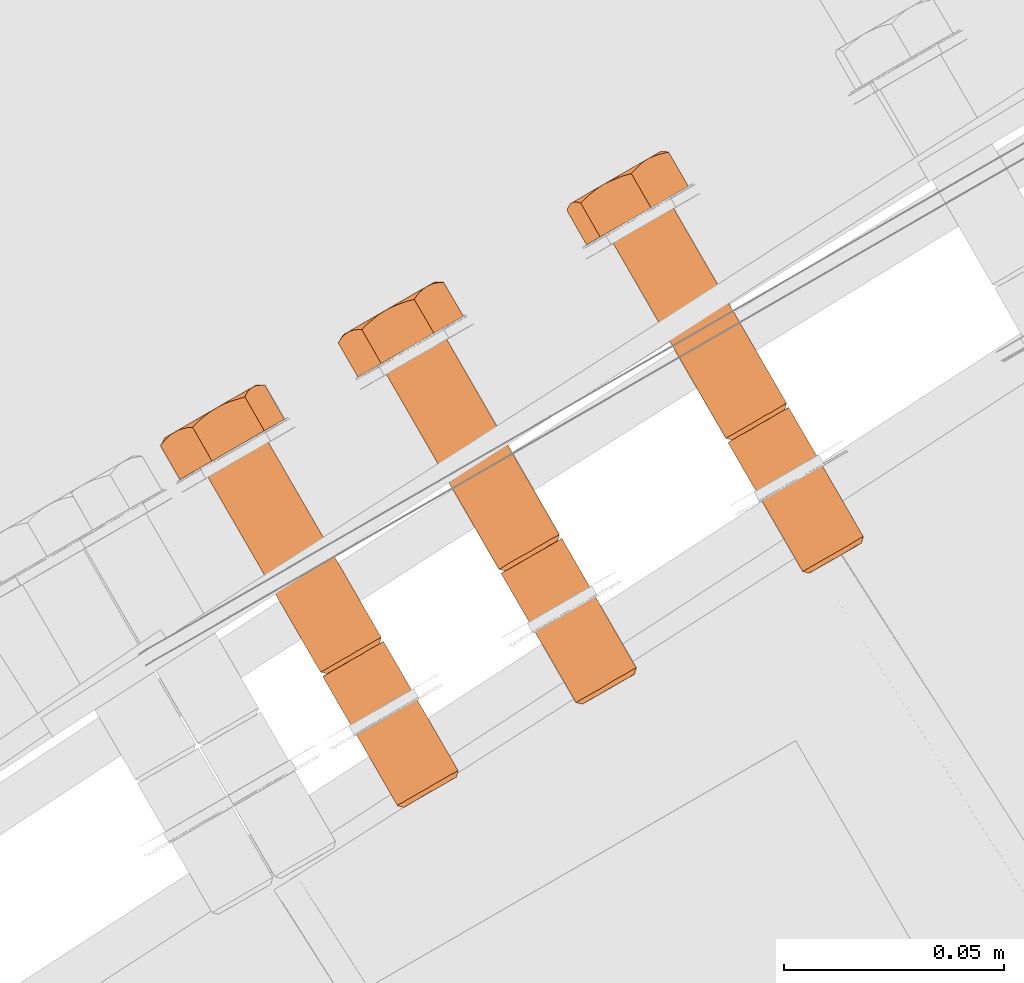
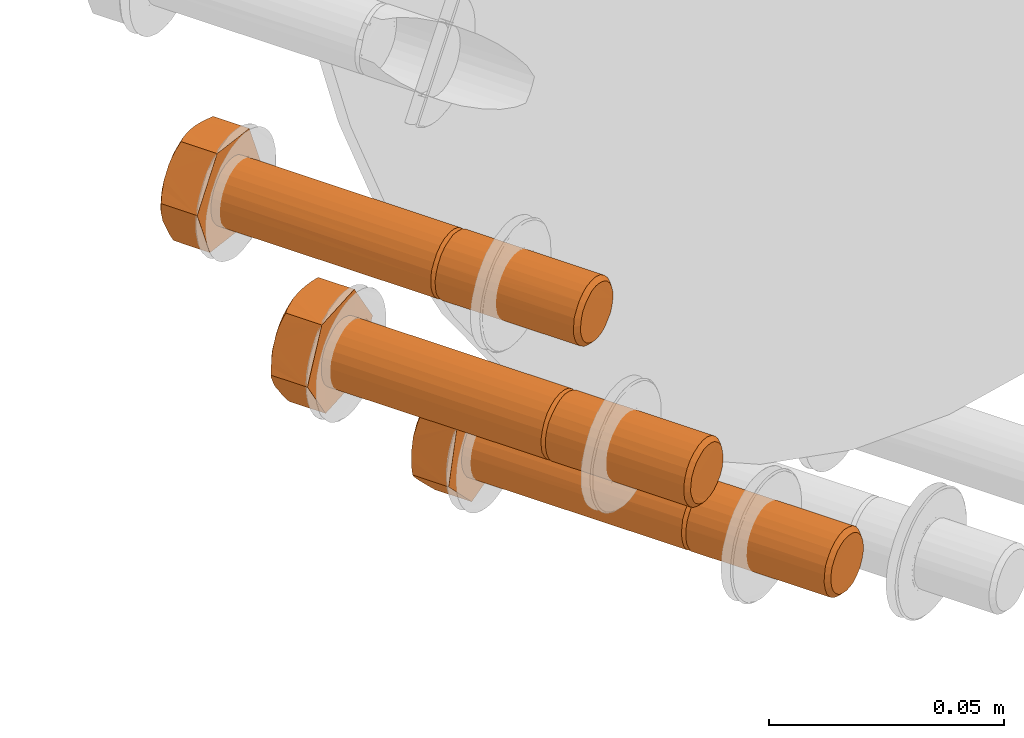
# One storey, part 76 of 126: 3 proxies.
"""IFC2X3 building model written with IfcOpenShell, lengths in millimetres."""

from ifc_helpers import new_model, si_unit, origin, origin_with_axes, place, context, project, spatial, faceted_brep, material, element, save


model = new_model("IFC2X3")

# Units and contexts
context_of_model_1 = context(None, 3, precision=0.1, world=origin())
context_of_model_2 = context(None, 3, precision=0.1, world=origin())
ifc_project = project(units=[si_unit("LENGTHUNIT", "METRE", prefix="MILLI"), si_unit("AREAUNIT", "SQUARE_METRE", prefix="CENTI"), si_unit("VOLUMEUNIT", "CUBIC_METRE", prefix="CENTI"), si_unit("MASSUNIT", "GRAM", prefix="KILO")], contexts=[context_of_model_1, context_of_model_2])

# Site, building, storey
site_placement = place(None, origin_with_axes())
site = spatial("IfcSite", under=ifc_project, at=site_placement, CompositionType="ELEMENT")
building_placement = place(site_placement, origin_with_axes())
building = spatial("IfcBuilding", under=site, at=building_placement, CompositionType="ELEMENT")
storey_placement = place(building_placement, origin_with_axes())
storey = spatial("IfcBuildingStorey", under=building, at=storey_placement, CompositionType="ELEMENT")

# Proxies
ifc_material = material(Name="STAHL")
proxy_1_placement = place(storey_placement, origin_with_axes())
element("IfcBuildingElementProxy", 1, at=proxy_1_placement, inside=storey, material=ifc_material, Name="profile", context=context_of_model_2, shape_type="Brep", body=[
    faceted_brep([(3788.3, 14751.2, 560.0), (3786.9, 14751.6, 559.5), (3788.0, 14752.2, 557.9), (3789.2, 14751.7, 558.7), (3787.7, 14750.8, 561.5), (3786.3, 14751.2, 561.2), (3787.4, 14750.7, 563.2), (3786.0, 14751.1, 563.1), (3787.5, 14750.7, 564.9), (3786.1, 14751.1, 565.0), (3787.9, 14751.0, 566.4), (3786.5, 14751.4, 566.9), (3788.7, 14751.4, 567.9), (3787.4, 14751.9, 568.5), (3789.7, 14752.0, 569.1), (3788.6, 14752.6, 569.9), (3790.9, 14752.7, 569.9), (3790.0, 14753.4, 570.9), (3792.3, 14753.5, 570.4), (3791.6, 14754.3, 571.5), (3793.8, 14754.3, 570.5), (3793.3, 14755.3, 571.6), (3795.2, 14755.1, 570.2), (3794.9, 14756.2, 571.2), (3796.5, 14755.9, 569.5), (3796.5, 14757.1, 570.5), (3797.6, 14756.6, 568.5), (3797.8, 14757.9, 569.3), (3769.4, 14781.9, 559.5), (3770.5, 14782.5, 557.9), (3771.7, 14782.0, 558.7), (3770.8, 14781.5, 560.0), (3768.8, 14781.5, 561.2), (3770.2, 14781.1, 561.5), (3768.5, 14781.4, 563.1), (3769.9, 14781.0, 563.2), (3768.6, 14781.4, 565.0), (3770.0, 14781.0, 564.9), (3769.0, 14781.7, 566.9), (3770.4, 14781.3, 566.4), (3769.9, 14782.2, 568.5), (3771.2, 14781.7, 567.9), (3771.1, 14782.9, 569.9), (3772.2, 14782.3, 569.1), (3772.5, 14783.7, 570.9), (3773.4, 14783.0, 569.9), (3774.1, 14784.6, 571.5), (3774.8, 14783.8, 570.4), (3775.8, 14785.6, 571.6), (3776.3, 14784.6, 570.5), (3777.4, 14786.6, 571.2), (3777.7, 14785.5, 570.2), (3779.0, 14787.4, 570.5), (3779.0, 14786.2, 569.5), (3780.3, 14788.2, 569.3), (3780.1, 14786.9, 568.5), (3771.0, 14781.6, 557.9), (3772.3, 14782.4, 556.8), (3789.3, 14753.0, 556.8), (3798.8, 14758.5, 567.7), (3781.8, 14787.8, 567.7), (3780.8, 14787.3, 569.3), (3799.5, 14758.9, 566.0), (3782.5, 14788.2, 566.0), (3799.8, 14759.0, 564.1), (3782.8, 14788.4, 564.1), (3799.7, 14759.0, 562.2), (3782.7, 14788.4, 562.2), (3799.2, 14758.7, 560.3), (3782.2, 14788.1, 560.3), (3798.3, 14758.2, 558.7), (3781.4, 14787.6, 558.7), (3797.1, 14757.5, 557.3), (3780.2, 14786.9, 557.3), (3795.7, 14756.7, 556.3), (3778.8, 14786.1, 556.3), (3794.1, 14755.8, 555.7), (3777.2, 14785.1, 555.7), (3792.4, 14754.8, 555.6), (3775.5, 14784.2, 555.6), (3790.8, 14753.9, 556.0), (3773.8, 14783.2, 556.0), (3742.5, 14828.6, 559.5), (3743.5, 14829.2, 557.9), (3741.8, 14828.2, 561.2), (3741.5, 14828.1, 563.1), (3741.6, 14828.1, 565.0), (3742.1, 14828.4, 566.9), (3743.0, 14828.9, 568.5), (3744.1, 14829.6, 569.9), (3745.6, 14830.4, 570.9), (3747.2, 14831.3, 571.5), (3748.8, 14832.3, 571.6), (3750.5, 14833.2, 571.2), (3752.0, 14834.1, 570.5), (3753.3, 14834.9, 569.3), (3771.8, 14783.3, 556.8), (3744.8, 14830.0, 556.8), (3746.3, 14830.9, 556.0), (3773.3, 14784.2, 556.0), (3781.3, 14788.8, 567.7), (3754.3, 14835.5, 567.7), (3782.0, 14789.2, 566.0), (3755.0, 14835.9, 566.0), (3782.3, 14789.4, 564.1), (3755.3, 14836.0, 564.1), (3782.2, 14789.3, 562.2), (3755.2, 14836.0, 562.2), (3781.7, 14789.0, 560.3), (3754.7, 14835.7, 560.3), (3780.8, 14788.5, 558.7), (3753.9, 14835.2, 558.7), (3779.6, 14787.8, 557.3), (3752.7, 14834.5, 557.3), (3778.2, 14787.0, 556.3), (3751.3, 14833.7, 556.3), (3776.6, 14786.1, 555.7), (3749.7, 14832.8, 555.7), (3774.9, 14785.1, 555.6), (3748.0, 14831.8, 555.6), (3736.8, 14825.4, 560.0), (3745.3, 14830.3, 550.2), (3756.9, 14837.0, 553.8), (3760.0, 14838.7, 567.2), (3751.5, 14833.8, 577.0), (3739.9, 14827.2, 573.4), (3752.4, 14844.7, 553.8), (3752.6, 14845.4, 555.7), (3752.9, 14845.9, 557.6), (3753.1, 14846.3, 559.0), (3753.4, 14846.5, 560.5), (3753.9, 14846.7, 562.3), (3754.5, 14846.7, 564.2), (3755.0, 14846.6, 565.6), (3755.5, 14846.5, 567.2), (3751.7, 14845.4, 571.0), (3752.7, 14845.8, 569.9), (3754.1, 14846.2, 568.6), (3753.8, 14846.7, 562.6), (3753.8, 14846.7, 564.7), (3753.4, 14846.5, 566.7), (3752.8, 14846.2, 568.7), (3751.9, 14845.6, 570.5), (3750.8, 14845.0, 572.1), (3746.1, 14842.3, 552.0), (3747.8, 14843.3, 552.7), (3749.4, 14844.2, 553.8), (3750.8, 14845.0, 555.1), (3751.9, 14845.6, 556.7), (3752.8, 14846.2, 558.5), (3750.9, 14844.3, 553.4), (3749.4, 14843.8, 553.0), (3747.7, 14843.1, 552.5), (3736.1, 14836.5, 555.1), (3737.4, 14837.3, 553.8), (3739.0, 14838.2, 552.7), (3740.7, 14839.2, 552.0), (3742.5, 14840.2, 551.7), (3744.3, 14841.2, 551.7), (3744.9, 14841.5, 551.6), (3743.7, 14840.6, 551.2), (3742.2, 14839.4, 550.7), (3740.8, 14838.0, 550.2), (3739.7, 14837.8, 551.3), (3738.6, 14837.5, 552.4), (3737.3, 14837.1, 553.8), (3749.6, 14844.2, 573.4), (3748.6, 14843.3, 574.8), (3747.8, 14842.5, 575.9), (3747.0, 14841.6, 577.0), (3745.1, 14841.1, 576.5), (3743.4, 14840.4, 576.0), (3742.0, 14839.8, 575.6), (3740.7, 14839.2, 575.2), (3739.2, 14838.2, 574.7), (3737.7, 14837.0, 574.2), (3736.6, 14836.0, 573.8), (3735.5, 14834.9, 573.4), (3732.4, 14833.1, 560.0), (3732.5, 14833.7, 561.6), (3732.7, 14834.1, 563.1), (3733.0, 14834.6, 564.9), (3733.4, 14834.9, 566.7), (3733.1, 14834.7, 564.7), (3733.1, 14834.7, 562.6), (3733.4, 14834.9, 560.5), (3734.0, 14835.3, 558.5), (3734.9, 14835.8, 556.7), (3735.2, 14835.9, 556.2), (3734.3, 14835.2, 557.3), (3733.3, 14834.2, 558.6), (3739.0, 14838.2, 574.5), (3737.4, 14837.3, 573.4), (3736.1, 14836.5, 572.1), (3734.9, 14835.8, 570.5), (3734.0, 14835.3, 568.7), (3734.2, 14835.1, 569.6), (3734.8, 14835.1, 571.5), (3733.7, 14835.1, 568.2), (3749.4, 14844.2, 573.4), (3747.8, 14843.3, 574.5), (3746.1, 14842.3, 575.2), (3744.3, 14841.2, 575.6), (3742.5, 14840.2, 575.6), (3769.0, 14780.4, 563.1), (3769.1, 14780.5, 565.0), (3769.6, 14780.8, 566.9), (3770.5, 14781.3, 568.5), (3771.6, 14782.0, 569.9), (3773.1, 14782.8, 570.9), (3774.7, 14783.7, 571.5), (3776.3, 14784.7, 571.6), (3778.0, 14785.6, 571.2), (3779.5, 14786.5, 570.5), (3770.0, 14781.0, 559.5), (3772.8, 14782.6, 557.7), (3774.1, 14783.4, 557.0), (3775.5, 14784.2, 556.7), (3777.0, 14785.0, 556.8), (3778.4, 14785.8, 557.3), (3779.6, 14786.6, 558.2), (3780.6, 14787.1, 559.3), (3781.4, 14787.6, 560.8), (3781.8, 14787.8, 562.4), (3781.9, 14787.9, 564.0), (3781.6, 14787.7, 565.7), (3781.0, 14787.4, 567.2), (3769.3, 14780.6, 561.2), (3790.3, 14752.3, 557.7), (3791.6, 14753.1, 557.0), (3793.0, 14753.9, 556.7), (3794.5, 14754.7, 556.8), (3795.9, 14755.5, 557.3), (3797.1, 14756.2, 558.2), (3798.1, 14756.8, 559.3), (3798.9, 14757.3, 560.8), (3799.3, 14757.5, 562.4), (3799.4, 14757.6, 564.0), (3799.1, 14757.4, 565.7), (3798.5, 14757.1, 567.2)], [[[0, 1, 2, 3]], [[4, 5, 1, 0]], [[6, 7, 5, 4]], [[8, 9, 7, 6]], [[10, 11, 9, 8]], [[12, 13, 11, 10]], [[14, 15, 13, 12]], [[16, 17, 15, 14]], [[18, 19, 17, 16]], [[20, 21, 19, 18]], [[22, 23, 21, 20]], [[24, 25, 23, 22]], [[26, 27, 25, 24]], [[28, 29, 30, 31]], [[32, 28, 31, 33]], [[34, 32, 33, 35]], [[36, 34, 35, 37]], [[38, 36, 37, 39]], [[40, 38, 39, 41]], [[42, 40, 41, 43]], [[44, 42, 43, 45]], [[46, 44, 45, 47]], [[48, 46, 47, 49]], [[50, 48, 49, 51]], [[52, 50, 51, 53]], [[54, 52, 53, 55]], [[2, 56, 57, 58]], [[59, 60, 61, 27]], [[62, 63, 60, 59]], [[64, 65, 63, 62]], [[66, 67, 65, 64]], [[68, 69, 67, 66]], [[70, 71, 69, 68]], [[72, 73, 71, 70]], [[74, 75, 73, 72]], [[76, 77, 75, 74]], [[78, 79, 77, 76]], [[80, 81, 79, 78]], [[58, 57, 81, 80]], [[29, 28, 82, 83]], [[28, 32, 84, 82]], [[32, 34, 85, 84]], [[34, 36, 86, 85]], [[36, 38, 87, 86]], [[38, 40, 88, 87]], [[40, 42, 89, 88]], [[42, 44, 90, 89]], [[44, 46, 91, 90]], [[46, 48, 92, 91]], [[48, 50, 93, 92]], [[50, 52, 94, 93]], [[54, 95, 94, 52]], [[96, 29, 83, 97]], [[96, 97, 98, 99]], [[54, 100, 101, 95]], [[102, 103, 101, 100]], [[104, 105, 103, 102]], [[106, 107, 105, 104]], [[108, 109, 107, 106]], [[110, 111, 109, 108]], [[112, 113, 111, 110]], [[114, 115, 113, 112]], [[116, 117, 115, 114]], [[118, 119, 117, 116]], [[99, 98, 119, 118]], [[120, 121, 122, 123, 124, 125, 120, 86, 87, 88, 89, 90, 91, 92, 93, 94, 95, 101, 103, 105, 107, 109, 111, 113, 115, 117, 119, 98, 97, 83, 82, 84, 85, 86]], [[122, 126, 127, 128, 129, 130, 131, 132, 133, 134, 123]], [[135, 136, 137, 134, 133, 132, 131, 130, 138, 139, 140, 141, 142]], [[143, 135, 142]], [[144, 145, 146, 147, 148, 149, 128, 127, 126, 150, 151, 152]], [[129, 128, 149]], [[130, 129, 149]], [[153, 154, 155, 156, 157, 158, 159, 160, 161, 162, 163, 164, 165]], [[144, 159, 158]], [[124, 123, 134, 137, 136, 135, 143, 166, 167, 168, 169]], [[125, 124, 169, 170, 171, 172, 173, 174, 175, 176, 177]], [[178, 179, 180, 181, 182, 183, 184, 185, 186, 187, 188, 189, 190]], [[153, 188, 187]], [[177, 176, 175, 174, 173, 191, 192, 193, 194, 195, 196, 197]], [[198, 196, 195]], [[182, 198, 195]], [[172, 171, 170, 169, 168, 167, 166, 143, 199, 200, 201, 202, 203]], [[173, 172, 203]], [[120, 125, 177, 197, 196, 198, 182, 181, 180, 179, 178]], [[120, 178, 190, 189, 188, 153, 165, 164, 163, 162, 121]], [[121, 162, 161, 160, 159, 144, 152, 151, 150, 126, 122]], [[183, 182, 195, 194, 193, 192, 191, 173, 203, 202, 201, 200, 199, 143, 142, 141, 140, 139, 138, 130, 149, 148, 147, 146, 145, 144, 158, 157, 156, 155, 154, 153, 187, 186, 185, 184]], [[204, 205, 206, 207, 208, 209, 210, 211, 212, 213, 61, 60, 63, 65, 67, 69, 71, 73, 75, 77, 79, 81, 57, 56, 214, 31, 30, 215, 216, 217, 218, 219, 220, 221, 222, 223, 224, 225, 226, 55, 53, 51, 49, 47, 45, 43, 41, 39, 37, 35, 33, 31, 214, 227]], [[100, 54, 55, 226]], [[102, 100, 226, 225]], [[104, 102, 225, 224]], [[106, 104, 224, 223]], [[108, 106, 223, 222]], [[110, 108, 222, 221]], [[112, 110, 221, 220]], [[114, 112, 220, 219]], [[116, 114, 219, 218]], [[118, 116, 218, 217]], [[99, 118, 217, 216]], [[96, 99, 216, 215]], [[30, 29, 96, 215]], [[27, 61, 213, 25]], [[1, 214, 56, 2]], [[5, 227, 214, 1]], [[7, 204, 227, 5]], [[9, 205, 204, 7]], [[11, 206, 205, 9]], [[13, 207, 206, 11]], [[15, 208, 207, 13]], [[17, 209, 208, 15]], [[19, 210, 209, 17]], [[21, 211, 210, 19]], [[23, 212, 211, 21]], [[25, 213, 212, 23]], [[6, 4, 0, 3, 228, 229, 230, 231, 232, 233, 234, 235, 236, 237, 238, 239, 26, 24, 22, 20, 18, 16, 14, 12, 10, 8]], [[59, 27, 26, 239]], [[62, 59, 239, 238]], [[64, 62, 238, 237]], [[66, 64, 237, 236]], [[68, 66, 236, 235]], [[70, 68, 235, 234]], [[72, 70, 234, 233]], [[74, 72, 233, 232]], [[76, 74, 232, 231]], [[78, 76, 231, 230]], [[80, 78, 230, 229]], [[58, 80, 229, 228]], [[2, 58, 228, 3]]]),
])
proxy_2_placement = place(storey_placement, origin_with_axes())
element("IfcBuildingElementProxy", 2, at=proxy_2_placement, inside=storey, material=ifc_material, Name="profile", context=context_of_model_2, shape_type="Brep", body=[
    faceted_brep([(3736.2, 14721.1, 620.9), (3734.7, 14721.5, 620.5), (3735.5, 14721.9, 618.8), (3736.8, 14721.4, 619.4), (3735.8, 14720.9, 622.5), (3734.4, 14721.3, 622.4), (3735.9, 14720.9, 624.1), (3734.4, 14721.3, 624.3), (3736.2, 14721.1, 625.8), (3734.8, 14721.5, 626.2), (3736.9, 14721.5, 627.2), (3735.6, 14722.0, 627.9), (3737.9, 14722.1, 628.5), (3736.7, 14722.6, 629.3), (3739.1, 14722.7, 629.4), (3738.1, 14723.4, 630.3), (3740.4, 14723.5, 630.0), (3739.7, 14724.3, 631.0), (3741.9, 14724.4, 630.1), (3741.4, 14725.3, 631.2), (3743.3, 14725.2, 629.9), (3743.0, 14726.3, 630.9), (3744.7, 14726.0, 629.3), (3744.6, 14727.2, 630.2), (3745.8, 14726.6, 628.3), (3745.9, 14727.9, 629.1), (3746.8, 14727.2, 627.1), (3747.0, 14728.6, 627.7), (3717.2, 14751.8, 620.5), (3718.0, 14752.2, 618.8), (3719.3, 14751.7, 619.4), (3718.7, 14751.4, 620.9), (3716.9, 14751.6, 622.4), (3718.3, 14751.2, 622.5), (3716.9, 14751.6, 624.3), (3718.4, 14751.2, 624.1), (3717.3, 14751.8, 626.2), (3718.7, 14751.4, 625.8), (3718.1, 14752.3, 627.9), (3719.4, 14751.8, 627.2), (3719.2, 14753.0, 629.3), (3720.4, 14752.4, 628.5), (3720.6, 14753.8, 630.3), (3721.6, 14753.1, 629.4), (3722.2, 14754.7, 631.0), (3722.9, 14753.8, 630.0), (3723.9, 14755.6, 631.2), (3724.4, 14754.7, 630.1), (3725.5, 14756.6, 630.9), (3725.8, 14755.5, 629.9), (3727.1, 14757.5, 630.2), (3727.2, 14756.3, 629.3), (3728.4, 14758.3, 629.1), (3728.3, 14757.0, 628.3), (3729.5, 14758.9, 627.7), (3729.3, 14757.5, 627.1), (3747.8, 14729.0, 625.9), (3730.8, 14758.4, 625.9), (3730.0, 14757.9, 627.7), (3748.1, 14729.2, 624.1), (3731.2, 14758.6, 624.1), (3748.1, 14729.2, 622.1), (3731.2, 14758.6, 622.1), (3747.7, 14729.0, 620.3), (3730.7, 14758.3, 620.3), (3746.9, 14728.5, 618.6), (3729.9, 14757.9, 618.6), (3745.8, 14727.9, 617.1), (3728.8, 14757.2, 617.1), (3744.4, 14727.1, 616.1), (3727.4, 14756.4, 616.1), (3742.8, 14726.1, 615.4), (3725.8, 14755.5, 615.4), (3741.1, 14725.2, 615.2), (3724.2, 14754.6, 615.2), (3739.5, 14724.2, 615.5), (3722.5, 14753.6, 615.5), (3737.9, 14723.3, 616.2), (3721.0, 14752.7, 616.2), (3736.6, 14722.5, 617.3), (3719.6, 14751.9, 617.3), (3718.5, 14751.3, 618.8), (3690.3, 14798.5, 620.5), (3691.0, 14798.9, 618.8), (3689.9, 14798.3, 622.4), (3689.9, 14798.3, 624.3), (3690.3, 14798.5, 626.2), (3691.1, 14799.0, 627.9), (3692.3, 14799.6, 629.3), (3693.7, 14800.4, 630.3), (3695.2, 14801.4, 631.0), (3696.9, 14802.3, 631.2), (3698.5, 14803.3, 630.9), (3700.1, 14804.2, 630.2), (3701.5, 14805.0, 629.1), (3702.5, 14805.6, 627.7), (3730.3, 14759.3, 625.9), (3703.3, 14806.0, 625.9), (3730.6, 14759.5, 624.1), (3703.7, 14806.2, 624.1), (3730.6, 14759.5, 622.1), (3703.7, 14806.2, 622.1), (3730.2, 14759.3, 620.3), (3703.2, 14806.0, 620.3), (3729.4, 14758.8, 618.6), (3702.4, 14805.5, 618.6), (3728.3, 14758.2, 617.1), (3701.3, 14804.9, 617.1), (3726.9, 14757.4, 616.1), (3699.9, 14804.1, 616.1), (3725.3, 14756.5, 615.4), (3698.3, 14803.2, 615.4), (3723.6, 14755.5, 615.2), (3696.7, 14802.2, 615.2), (3722.0, 14754.5, 615.5), (3695.0, 14801.2, 615.5), (3720.4, 14753.6, 616.2), (3693.5, 14800.3, 616.2), (3719.1, 14752.9, 617.3), (3692.1, 14799.6, 617.3), (3684.8, 14795.3, 622.3), (3691.5, 14799.2, 610.8), (3703.5, 14806.1, 611.7), (3708.8, 14809.2, 624.1), (3702.1, 14805.3, 635.6), (3690.1, 14798.4, 634.7), (3699.0, 14813.8, 611.7), (3699.5, 14814.7, 613.5), (3700.1, 14815.4, 615.2), (3700.6, 14815.9, 616.5), (3701.1, 14816.3, 617.9), (3701.9, 14816.6, 619.6), (3702.7, 14816.8, 621.3), (3703.5, 14816.9, 622.7), (3704.3, 14816.9, 624.1), (3701.8, 14816.7, 619.9), (3702.1, 14816.9, 621.9), (3702.2, 14816.9, 624.0), (3701.9, 14816.7, 626.1), (3701.3, 14816.4, 628.0), (3701.2, 14816.3, 628.6), (3702.0, 14816.6, 627.3), (3703.1, 14816.8, 625.8), (3700.4, 14815.9, 629.9), (3692.5, 14811.3, 611.2), (3694.3, 14812.3, 611.6), (3696.0, 14813.3, 612.2), (3697.6, 14814.2, 613.2), (3699.0, 14815.1, 614.5), (3700.2, 14815.8, 616.1), (3697.4, 14813.4, 611.6), (3695.9, 14812.9, 611.5), (3694.1, 14812.2, 611.4), (3683.1, 14805.9, 616.5), (3684.3, 14806.6, 614.9), (3685.6, 14807.4, 613.5), (3687.2, 14808.3, 612.4), (3688.9, 14809.2, 611.7), (3690.7, 14810.3, 611.3), (3691.2, 14810.5, 611.1), (3690.0, 14809.6, 611.0), (3688.5, 14808.4, 610.9), (3687.0, 14806.9, 610.8), (3686.0, 14806.8, 612.1), (3685.1, 14806.7, 613.4), (3684.1, 14806.4, 615.0), (3699.6, 14815.3, 631.5), (3698.8, 14814.6, 633.0), (3698.2, 14813.9, 634.3), (3697.6, 14813.0, 635.6), (3695.7, 14812.5, 635.5), (3693.8, 14811.8, 635.4), (3692.4, 14811.2, 635.3), (3691.1, 14810.5, 635.2), (3689.5, 14809.5, 635.1), (3688.0, 14808.3, 634.9), (3686.8, 14807.3, 634.8), (3685.7, 14806.1, 634.7), (3680.3, 14803.1, 622.3), (3680.8, 14803.8, 623.7), (3681.2, 14804.4, 625.1), (3681.8, 14805.0, 626.8), (3682.5, 14805.5, 628.5), (3681.8, 14805.2, 626.6), (3681.5, 14804.9, 624.5), (3681.4, 14804.9, 622.4), (3681.7, 14805.1, 620.4), (3682.3, 14805.4, 618.4), (3682.4, 14805.5, 617.8), (3681.8, 14804.9, 619.1), (3681.0, 14804.1, 620.7), (3683.7, 14806.0, 631.2), (3684.6, 14806.1, 632.9), (3689.3, 14809.5, 634.9), (3687.6, 14808.5, 634.2), (3686.0, 14807.6, 633.2), (3684.6, 14806.8, 631.9), (3683.4, 14806.1, 630.3), (3683.1, 14805.8, 629.9), (3699.3, 14815.2, 631.5), (3697.9, 14814.5, 632.9), (3696.4, 14813.6, 634.0), (3694.7, 14812.6, 634.7), (3692.9, 14811.6, 635.1), (3717.4, 14750.6, 622.4), (3717.4, 14750.7, 624.3), (3717.8, 14750.9, 626.2), (3718.6, 14751.4, 627.9), (3719.8, 14752.0, 629.3), (3721.2, 14752.8, 630.3), (3722.7, 14753.7, 631.0), (3724.4, 14754.7, 631.2), (3726.0, 14755.6, 630.9), (3727.6, 14756.5, 630.2), (3729.0, 14757.3, 629.1), (3717.8, 14750.9, 620.5), (3720.2, 14752.3, 618.1), (3721.4, 14753.0, 617.1), (3722.8, 14753.7, 616.5), (3724.2, 14754.6, 616.3), (3725.6, 14755.4, 616.5), (3727.0, 14756.2, 617.0), (3728.2, 14756.9, 618.0), (3729.2, 14757.4, 619.2), (3729.9, 14757.8, 620.7), (3730.2, 14758.0, 622.3), (3730.2, 14758.1, 623.9), (3729.9, 14757.9, 625.6), (3737.7, 14722.0, 618.1), (3738.9, 14722.7, 617.1), (3740.3, 14723.4, 616.5), (3741.7, 14724.3, 616.3), (3743.1, 14725.1, 616.5), (3744.5, 14725.9, 617.0), (3745.7, 14726.6, 618.0), (3746.7, 14727.1, 619.2), (3747.4, 14727.5, 620.7), (3747.7, 14727.7, 622.3), (3747.7, 14727.8, 623.9), (3747.4, 14727.6, 625.6)], [[[0, 1, 2, 3]], [[4, 5, 1, 0]], [[6, 7, 5, 4]], [[8, 9, 7, 6]], [[10, 11, 9, 8]], [[12, 13, 11, 10]], [[14, 15, 13, 12]], [[16, 17, 15, 14]], [[18, 19, 17, 16]], [[20, 21, 19, 18]], [[22, 23, 21, 20]], [[24, 25, 23, 22]], [[26, 27, 25, 24]], [[28, 29, 30, 31]], [[32, 28, 31, 33]], [[34, 32, 33, 35]], [[36, 34, 35, 37]], [[38, 36, 37, 39]], [[40, 38, 39, 41]], [[42, 40, 41, 43]], [[44, 42, 43, 45]], [[46, 44, 45, 47]], [[48, 46, 47, 49]], [[50, 48, 49, 51]], [[52, 50, 51, 53]], [[54, 52, 53, 55]], [[27, 56, 57, 58]], [[56, 59, 60, 57]], [[59, 61, 62, 60]], [[61, 63, 64, 62]], [[63, 65, 66, 64]], [[65, 67, 68, 66]], [[67, 69, 70, 68]], [[69, 71, 72, 70]], [[71, 73, 74, 72]], [[73, 75, 76, 74]], [[75, 77, 78, 76]], [[77, 79, 80, 78]], [[79, 2, 81, 80]], [[29, 28, 82, 83]], [[28, 32, 84, 82]], [[32, 34, 85, 84]], [[34, 36, 86, 85]], [[36, 38, 87, 86]], [[38, 40, 88, 87]], [[40, 42, 89, 88]], [[42, 44, 90, 89]], [[44, 46, 91, 90]], [[46, 48, 92, 91]], [[48, 50, 93, 92]], [[50, 52, 94, 93]], [[54, 95, 94, 52]], [[96, 97, 95, 54]], [[96, 98, 99, 97]], [[98, 100, 101, 99]], [[100, 102, 103, 101]], [[102, 104, 105, 103]], [[104, 106, 107, 105]], [[106, 108, 109, 107]], [[108, 110, 111, 109]], [[110, 112, 113, 111]], [[112, 114, 115, 113]], [[114, 116, 117, 115]], [[116, 118, 119, 117]], [[29, 83, 119, 118]], [[120, 121, 122, 123, 124, 125, 120, 86, 87, 88, 89, 90, 91, 92, 93, 94, 95, 97, 99, 101, 103, 105, 107, 109, 111, 113, 115, 117, 119, 83, 82, 84, 85, 86]], [[122, 126, 127, 128, 129, 130, 131, 132, 133, 134, 123]], [[130, 135, 136, 137, 138, 139, 140, 141, 142, 134, 133, 132, 131]], [[143, 140, 139]], [[144, 145, 146, 147, 148, 149, 128, 127, 126, 150, 151, 152]], [[129, 128, 149]], [[130, 129, 149]], [[153, 154, 155, 156, 157, 158, 159, 160, 161, 162, 163, 164, 165]], [[144, 159, 158]], [[124, 123, 134, 142, 141, 140, 143, 166, 167, 168, 169]], [[125, 124, 169, 170, 171, 172, 173, 174, 175, 176, 177]], [[178, 179, 180, 181, 182, 183, 184, 185, 186, 187, 188, 189, 190]], [[153, 188, 187]], [[191, 192, 177, 176, 175, 174, 173, 193, 194, 195, 196, 197]], [[198, 191, 197]], [[182, 198, 197]], [[172, 171, 170, 169, 168, 167, 166, 143, 199, 200, 201, 202, 203]], [[173, 172, 203]], [[120, 125, 177, 192, 191, 198, 182, 181, 180, 179, 178]], [[120, 178, 190, 189, 188, 153, 165, 164, 163, 162, 121]], [[121, 162, 161, 160, 159, 144, 152, 151, 150, 126, 122]], [[185, 184, 183, 182, 197, 196, 195, 194, 193, 173, 203, 202, 201, 200, 199, 143, 139, 138, 137, 136, 135, 130, 149, 148, 147, 146, 145, 144, 158, 157, 156, 155, 154, 153, 187, 186]], [[204, 205, 206, 207, 208, 209, 210, 211, 212, 213, 214, 58, 57, 60, 62, 64, 66, 68, 70, 72, 74, 76, 78, 80, 81, 215, 31, 30, 216, 217, 218, 219, 220, 221, 222, 223, 224, 225, 226, 227, 55, 53, 51, 49, 47, 45, 43, 41, 39, 37, 35, 33, 31, 215]], [[96, 54, 55, 227]], [[98, 96, 227, 226]], [[100, 98, 226, 225]], [[102, 100, 225, 224]], [[104, 102, 224, 223]], [[106, 104, 223, 222]], [[108, 106, 222, 221]], [[110, 108, 221, 220]], [[112, 110, 220, 219]], [[114, 112, 219, 218]], [[116, 114, 218, 217]], [[118, 116, 217, 216]], [[30, 29, 118, 216]], [[27, 58, 214, 25]], [[2, 1, 215, 81]], [[5, 204, 215, 1]], [[7, 205, 204, 5]], [[9, 206, 205, 7]], [[11, 207, 206, 9]], [[13, 208, 207, 11]], [[15, 209, 208, 13]], [[17, 210, 209, 15]], [[19, 211, 210, 17]], [[21, 212, 211, 19]], [[23, 213, 212, 21]], [[25, 214, 213, 23]], [[4, 0, 3, 228, 229, 230, 231, 232, 233, 234, 235, 236, 237, 238, 239, 26, 24, 22, 20, 18, 16, 14, 12, 10, 8, 6]], [[56, 27, 26, 239]], [[59, 56, 239, 238]], [[61, 59, 238, 237]], [[63, 61, 237, 236]], [[65, 63, 236, 235]], [[67, 65, 235, 234]], [[69, 67, 234, 233]], [[71, 69, 233, 232]], [[73, 71, 232, 231]], [[75, 73, 231, 230]], [[77, 75, 230, 229]], [[79, 77, 229, 228]], [[2, 79, 228, 3]]]),
])
proxy_3_placement = place(storey_placement, origin_with_axes())
element("IfcBuildingElementProxy", 3, at=proxy_3_placement, inside=storey, material=ifc_material, Name="profile", context=context_of_model_2, shape_type="Brep", body=[
    faceted_brep([(3693.8, 14697.9, 692.1), (3694.3, 14698.1, 690.2), (3695.7, 14697.7, 690.7), (3695.3, 14697.5, 692.3), (3695.3, 14697.4, 693.9), (3693.8, 14697.8, 694.0), (3695.6, 14697.6, 695.6), (3694.1, 14698.1, 695.9), (3696.2, 14698.0, 697.1), (3694.9, 14698.5, 697.6), (3697.1, 14698.5, 698.3), (3695.9, 14699.1, 699.1), (3698.3, 14699.2, 699.3), (3697.3, 14699.9, 700.3), (3699.6, 14700.0, 700.0), (3698.8, 14700.8, 701.0), (3701.0, 14700.8, 700.2), (3700.5, 14701.7, 701.3), (3702.5, 14701.6, 700.1), (3702.1, 14702.7, 701.1), (3703.9, 14702.4, 699.5), (3703.7, 14703.6, 700.5), (3705.1, 14703.1, 698.6), (3705.1, 14704.4, 699.4), (3706.1, 14703.7, 697.4), (3706.3, 14705.1, 698.0), (3706.8, 14704.1, 695.9), (3707.1, 14705.5, 696.4), (3677.8, 14727.8, 692.3), (3676.3, 14728.2, 692.1), (3676.8, 14728.4, 690.2), (3678.2, 14728.0, 690.7), (3677.8, 14727.8, 693.9), (3676.3, 14728.2, 694.0), (3678.1, 14727.9, 695.6), (3676.6, 14728.4, 695.9), (3678.7, 14728.3, 697.1), (3677.4, 14728.8, 697.6), (3679.6, 14728.8, 698.3), (3678.4, 14729.4, 699.1), (3680.8, 14729.5, 699.3), (3679.8, 14730.2, 700.3), (3682.1, 14730.3, 700.0), (3681.3, 14731.1, 701.0), (3683.5, 14731.1, 700.2), (3683.0, 14732.0, 701.3), (3685.0, 14731.9, 700.1), (3684.6, 14733.0, 701.1), (3686.4, 14732.7, 699.5), (3686.2, 14733.9, 700.5), (3687.6, 14733.4, 698.6), (3687.6, 14734.7, 699.4), (3688.6, 14734.0, 697.4), (3688.8, 14735.4, 698.0), (3689.3, 14734.4, 695.9), (3689.6, 14735.8, 696.4), (3677.3, 14727.5, 690.2), (3678.2, 14728.0, 688.6), (3695.1, 14698.6, 688.6), (3707.5, 14705.8, 694.5), (3690.6, 14735.2, 694.5), (3690.1, 14734.9, 696.4), (3707.6, 14705.8, 692.6), (3690.6, 14735.2, 692.6), (3707.2, 14705.6, 690.7), (3690.3, 14735.0, 690.7), (3706.5, 14705.2, 689.0), (3689.5, 14734.6, 689.0), (3705.4, 14704.6, 687.5), (3688.5, 14733.9, 687.5), (3704.1, 14703.8, 686.3), (3687.1, 14733.2, 686.3), (3702.6, 14702.9, 685.6), (3685.6, 14732.3, 685.6), (3700.9, 14702.0, 685.3), (3683.9, 14731.3, 685.3), (3699.2, 14701.0, 685.5), (3682.3, 14730.4, 685.5), (3697.7, 14700.1, 686.1), (3680.7, 14729.5, 686.1), (3696.3, 14699.3, 687.2), (3679.3, 14728.6, 687.2), (3649.4, 14774.9, 692.1), (3649.8, 14775.1, 690.2), (3649.3, 14774.9, 694.0), (3649.7, 14775.1, 695.9), (3650.4, 14775.5, 697.6), (3651.5, 14776.1, 699.1), (3652.8, 14776.9, 700.3), (3654.4, 14777.8, 701.0), (3656.0, 14778.7, 701.3), (3657.7, 14779.7, 701.1), (3659.3, 14780.6, 700.5), (3660.7, 14781.4, 699.4), (3661.8, 14782.1, 698.0), (3662.6, 14782.5, 696.4), (3677.6, 14728.9, 688.6), (3650.7, 14775.6, 688.6), (3651.8, 14776.3, 687.2), (3678.8, 14729.6, 687.2), (3690.0, 14736.1, 694.5), (3663.1, 14782.8, 694.5), (3690.1, 14736.1, 692.6), (3663.1, 14782.8, 692.6), (3689.7, 14735.9, 690.7), (3662.8, 14782.6, 690.7), (3689.0, 14735.5, 689.0), (3662.0, 14782.2, 689.0), (3687.9, 14734.9, 687.5), (3661.0, 14781.6, 687.5), (3686.6, 14734.1, 686.3), (3659.6, 14780.8, 686.3), (3685.1, 14733.2, 685.6), (3658.1, 14779.9, 685.6), (3683.4, 14732.3, 685.3), (3656.4, 14779.0, 685.3), (3681.7, 14731.3, 685.5), (3654.8, 14778.0, 685.5), (3680.2, 14730.4, 686.1), (3653.2, 14777.1, 686.1), (3644.3, 14772.0, 695.1), (3648.9, 14774.6, 682.3), (3660.8, 14781.5, 680.5), (3668.1, 14785.7, 691.5), (3663.5, 14783.1, 704.3), (3651.6, 14776.2, 706.1), (3656.4, 14789.2, 680.5), (3657.2, 14790.3, 682.1), (3658.0, 14791.1, 683.6), (3658.7, 14791.8, 684.8), (3659.5, 14792.3, 686.0), (3660.5, 14792.8, 687.5), (3661.6, 14793.1, 689.0), (3662.6, 14793.3, 690.2), (3663.7, 14793.4, 691.5), (3660.4, 14792.8, 687.8), (3661.1, 14793.2, 689.7), (3661.5, 14793.4, 691.7), (3661.6, 14793.5, 693.8), (3661.4, 14793.4, 695.9), (3661.4, 14793.3, 696.5), (3661.9, 14793.4, 695.1), (3662.8, 14793.5, 693.3), (3660.8, 14793.0, 697.9), (3649.9, 14786.7, 681.4), (3651.7, 14787.8, 681.3), (3653.5, 14788.8, 681.6), (3655.2, 14789.8, 682.2), (3656.8, 14790.7, 683.2), (3658.3, 14791.6, 684.5), (3654.8, 14788.8, 680.7), (3653.3, 14788.3, 680.9), (3651.5, 14787.6, 681.2), (3641.6, 14782.0, 688.7), (3642.5, 14782.4, 686.9), (3643.6, 14783.1, 685.2), (3644.9, 14783.8, 683.8), (3646.4, 14784.7, 682.7), (3648.1, 14785.7, 681.9), (3648.6, 14785.9, 681.6), (3647.4, 14785.0, 681.8), (3645.9, 14783.8, 682.0), (3644.5, 14782.4, 682.3), (3643.7, 14782.4, 683.8), (3643.1, 14782.4, 685.2), (3642.3, 14782.2, 687.0), (3660.2, 14792.6, 699.6), (3659.7, 14792.0, 701.4), (3659.4, 14791.5, 702.8), (3659.1, 14790.8, 704.3), (3657.1, 14790.2, 704.6), (3655.3, 14789.6, 704.8), (3653.9, 14789.0, 705.0), (3652.6, 14788.3, 705.2), (3651.0, 14787.3, 705.4), (3649.5, 14786.1, 705.7), (3648.3, 14785.1, 705.9), (3647.2, 14783.9, 706.1), (3639.9, 14779.7, 695.1), (3640.5, 14780.6, 696.4), (3641.2, 14781.3, 697.6), (3642.0, 14782.1, 699.1), (3643.0, 14782.7, 700.6), (3642.0, 14782.2, 698.8), (3641.3, 14781.8, 696.9), (3640.9, 14781.5, 694.9), (3640.8, 14781.5, 692.8), (3641.1, 14781.6, 690.7), (3641.2, 14781.6, 690.1), (3640.7, 14781.2, 691.5), (3640.3, 14780.5, 693.3), (3643.8, 14783.2, 701.8), (3644.7, 14783.5, 703.0), (3645.9, 14783.8, 704.5), (3650.8, 14787.2, 705.3), (3649.0, 14786.2, 705.0), (3647.3, 14785.2, 704.4), (3645.6, 14784.3, 703.4), (3644.2, 14783.4, 702.1), (3654.4, 14789.3, 704.7), (3660.0, 14792.6, 699.7), (3658.9, 14791.9, 701.4), (3657.6, 14791.2, 702.8), (3656.0, 14790.3, 703.9), (3676.8, 14727.2, 694.0), (3677.2, 14727.4, 695.9), (3677.9, 14727.8, 697.6), (3679.0, 14728.5, 699.1), (3680.3, 14729.2, 700.3), (3681.9, 14730.1, 701.0), (3683.5, 14731.1, 701.3), (3685.2, 14732.0, 701.1), (3686.8, 14733.0, 700.5), (3688.2, 14733.8, 699.4), (3689.3, 14734.4, 698.0), (3676.9, 14727.3, 692.1), (3678.9, 14728.4, 689.2), (3679.9, 14729.0, 688.0), (3681.1, 14729.7, 687.1), (3682.5, 14730.5, 686.5), (3683.9, 14731.3, 686.4), (3685.3, 14732.1, 686.6), (3686.7, 14732.9, 687.3), (3687.8, 14733.6, 688.3), (3688.8, 14734.1, 689.5), (3689.4, 14734.5, 691.0), (3689.7, 14734.7, 692.7), (3689.7, 14734.6, 694.3), (3696.4, 14698.1, 689.2), (3697.4, 14698.7, 688.0), (3698.6, 14699.4, 687.1), (3700.0, 14700.2, 686.5), (3701.4, 14701.0, 686.4), (3702.8, 14701.8, 686.6), (3704.2, 14702.6, 687.3), (3705.3, 14703.3, 688.3), (3706.3, 14703.8, 689.5), (3706.9, 14704.2, 691.0), (3707.2, 14704.3, 692.7), (3707.2, 14704.3, 694.3)], [[[0, 1, 2, 3]], [[4, 5, 0, 3]], [[6, 7, 5, 4]], [[8, 9, 7, 6]], [[10, 11, 9, 8]], [[12, 13, 11, 10]], [[14, 15, 13, 12]], [[16, 17, 15, 14]], [[18, 19, 17, 16]], [[20, 21, 19, 18]], [[22, 23, 21, 20]], [[24, 25, 23, 22]], [[26, 27, 25, 24]], [[28, 29, 30, 31]], [[32, 33, 29, 28]], [[34, 35, 33, 32]], [[36, 37, 35, 34]], [[38, 39, 37, 36]], [[40, 41, 39, 38]], [[42, 43, 41, 40]], [[44, 45, 43, 42]], [[46, 47, 45, 44]], [[48, 49, 47, 46]], [[50, 51, 49, 48]], [[52, 53, 51, 50]], [[54, 55, 53, 52]], [[1, 56, 57, 58]], [[59, 60, 61, 27]], [[62, 63, 60, 59]], [[64, 65, 63, 62]], [[66, 67, 65, 64]], [[68, 69, 67, 66]], [[70, 71, 69, 68]], [[72, 73, 71, 70]], [[74, 75, 73, 72]], [[76, 77, 75, 74]], [[78, 79, 77, 76]], [[80, 81, 79, 78]], [[58, 57, 81, 80]], [[30, 29, 82, 83]], [[29, 33, 84, 82]], [[33, 35, 85, 84]], [[35, 37, 86, 85]], [[37, 39, 87, 86]], [[39, 41, 88, 87]], [[41, 43, 89, 88]], [[43, 45, 90, 89]], [[45, 47, 91, 90]], [[47, 49, 92, 91]], [[49, 51, 93, 92]], [[51, 53, 94, 93]], [[53, 55, 95, 94]], [[96, 97, 98, 99]], [[30, 83, 97, 96]], [[55, 100, 101, 95]], [[102, 103, 101, 100]], [[104, 105, 103, 102]], [[106, 107, 105, 104]], [[108, 109, 107, 106]], [[110, 111, 109, 108]], [[112, 113, 111, 110]], [[114, 115, 113, 112]], [[116, 117, 115, 114]], [[118, 119, 117, 116]], [[99, 98, 119, 118]], [[120, 121, 122, 123, 124, 125, 120, 86, 87, 88, 89, 90, 91, 92, 93, 94, 95, 101, 103, 105, 107, 109, 111, 113, 115, 117, 119, 98, 97, 83, 82, 84, 85, 86]], [[122, 126, 127, 128, 129, 130, 131, 132, 133, 134, 123]], [[130, 135, 136, 137, 138, 139, 140, 141, 142, 134, 133, 132, 131]], [[143, 140, 139]], [[144, 145, 146, 147, 148, 149, 129, 128, 127, 126, 150, 151, 152]], [[130, 129, 149]], [[153, 154, 155, 156, 157, 158, 159, 160, 161, 162, 163, 164, 165]], [[144, 159, 158]], [[124, 123, 134, 142, 141, 140, 143, 166, 167, 168, 169]], [[125, 124, 169, 170, 171, 172, 173, 174, 175, 176, 177]], [[178, 179, 180, 181, 182, 183, 184, 185, 186, 187, 188, 189, 190]], [[153, 188, 187]], [[191, 192, 193, 177, 176, 175, 174, 173, 194, 195, 196, 197, 198]], [[182, 191, 198]], [[199, 171, 170, 169, 168, 167, 166, 143, 200, 201, 202, 203]], [[172, 171, 199]], [[173, 172, 199]], [[120, 125, 177, 193, 192, 191, 182, 181, 180, 179, 178]], [[120, 178, 190, 189, 188, 153, 165, 164, 163, 162, 121]], [[121, 162, 161, 160, 159, 144, 152, 151, 150, 126, 122]], [[186, 185, 184, 183, 182, 198, 197, 196, 195, 194, 173, 199, 203, 202, 201, 200, 143, 139, 138, 137, 136, 135, 130, 149, 148, 147, 146, 145, 144, 158, 157, 156, 155, 154, 153, 187]], [[204, 205, 206, 207, 208, 209, 210, 211, 212, 213, 214, 61, 60, 63, 65, 67, 69, 71, 73, 75, 77, 79, 81, 57, 56, 215, 28, 31, 216, 217, 218, 219, 220, 221, 222, 223, 224, 225, 226, 227, 54, 52, 50, 48, 46, 44, 42, 40, 38, 36, 34, 32, 28, 215]], [[227, 100, 55, 54]], [[226, 102, 100, 227]], [[225, 104, 102, 226]], [[224, 106, 104, 225]], [[223, 108, 106, 224]], [[222, 110, 108, 223]], [[221, 112, 110, 222]], [[220, 114, 112, 221]], [[219, 116, 114, 220]], [[218, 118, 116, 219]], [[217, 99, 118, 218]], [[216, 96, 99, 217]], [[30, 96, 216, 31]], [[27, 61, 214, 25]], [[0, 215, 56, 1]], [[5, 204, 215, 0]], [[7, 205, 204, 5]], [[9, 206, 205, 7]], [[11, 207, 206, 9]], [[13, 208, 207, 11]], [[15, 209, 208, 13]], [[17, 210, 209, 15]], [[19, 211, 210, 17]], [[21, 212, 211, 19]], [[23, 213, 212, 21]], [[25, 214, 213, 23]], [[4, 3, 2, 228, 229, 230, 231, 232, 233, 234, 235, 236, 237, 238, 239, 26, 24, 22, 20, 18, 16, 14, 12, 10, 8, 6]], [[239, 59, 27, 26]], [[238, 62, 59, 239]], [[237, 64, 62, 238]], [[236, 66, 64, 237]], [[235, 68, 66, 236]], [[234, 70, 68, 235]], [[233, 72, 70, 234]], [[232, 74, 72, 233]], [[231, 76, 74, 232]], [[230, 78, 76, 231]], [[229, 80, 78, 230]], [[228, 58, 80, 229]], [[2, 1, 58, 228]]]),
])

save(model, "model.ifc")
